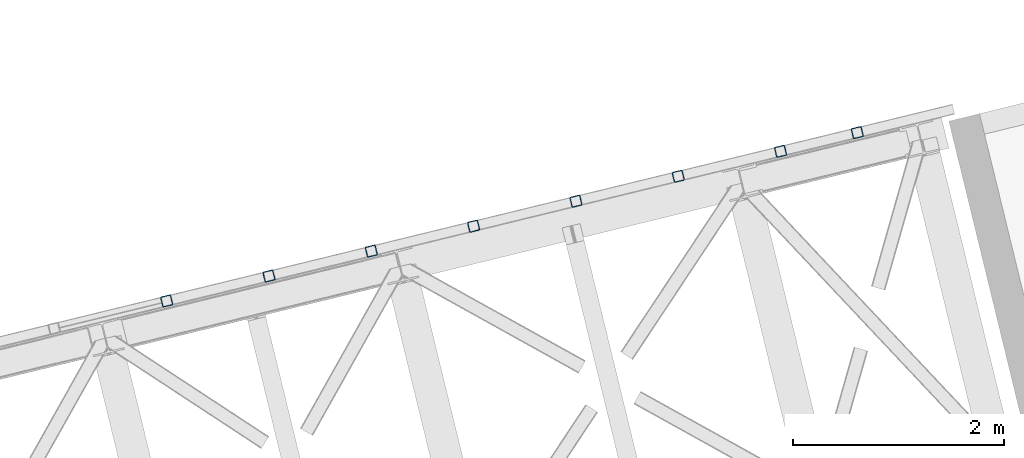
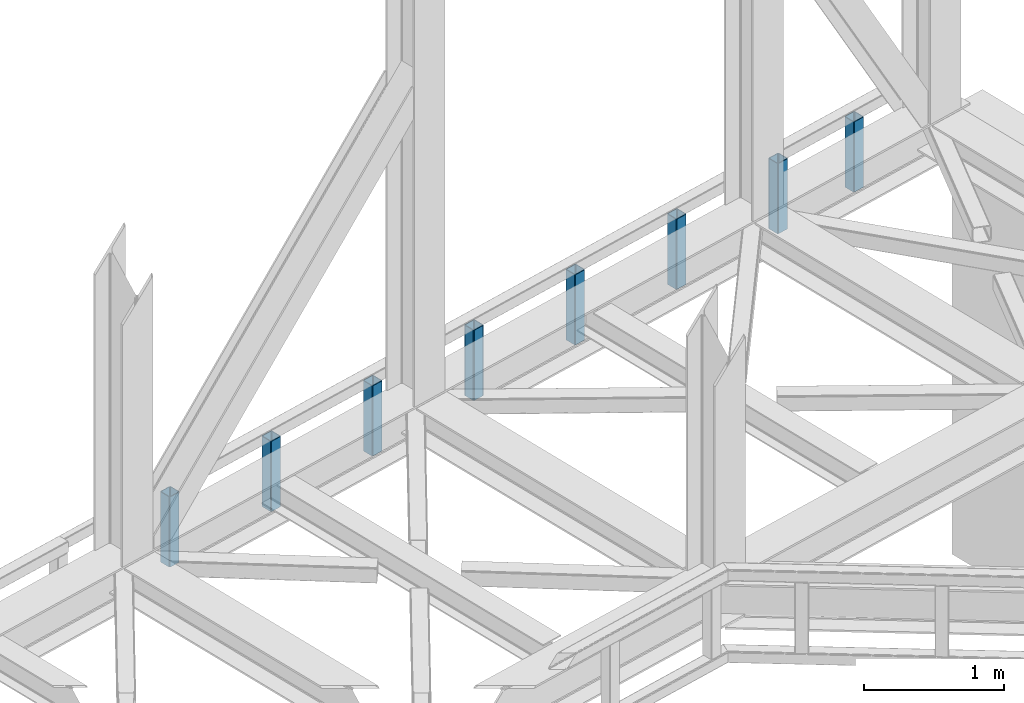
# One storey, part 14 of 93: 8 columns.
"""IFC4 building model written with IfcOpenShell, lengths in millimetres."""

from ifc_helpers import new_model, entity, si_unit, converted_unit, derived_unit, direction, frame, origin, place, context, subcontext, project, spatial, indexed_curve, outline, extrude, type_object, element, save


model = new_model("IFC4")

# Units and contexts
model_context = context("Model", 3, precision=0.01, world=origin(), true_north=direction((6.12303176911189e-17, 1.0)))
plan_context = context("Plan", 3, precision=0.01, world=origin(), true_north=direction((6.12303176911189e-17, 1.0)))
body_context = subcontext(model_context, "Body", "Model", "MODEL_VIEW")
ifc_project = project(units=[si_unit("LENGTHUNIT", "METRE", prefix="MILLI"), si_unit("AREAUNIT", "SQUARE_METRE"), si_unit("VOLUMEUNIT", "CUBIC_METRE"), converted_unit("PLANEANGLEUNIT", "DEGREE", entity("IfcRatioMeasure", 0.0174532925199433), si_unit("PLANEANGLEUNIT", "RADIAN"), dimensions=[0, 0, 0, 0, 0, 0, 0]), si_unit("MASSUNIT", "GRAM", prefix="KILO"), derived_unit("MASSDENSITYUNIT", [(si_unit("MASSUNIT", "GRAM", prefix="KILO"), 1), (si_unit("LENGTHUNIT", "METRE"), -3)]), derived_unit("MOMENTOFINERTIAUNIT", [(si_unit("LENGTHUNIT", "METRE"), 4)]), si_unit("TIMEUNIT", "SECOND"), si_unit("FREQUENCYUNIT", "HERTZ"), si_unit("THERMODYNAMICTEMPERATUREUNIT", "DEGREE_CELSIUS"), derived_unit("THERMALTRANSMITTANCEUNIT", [(si_unit("MASSUNIT", "GRAM", prefix="KILO"), 1), (si_unit("THERMODYNAMICTEMPERATUREUNIT", "KELVIN"), -1), (si_unit("TIMEUNIT", "SECOND"), -3)]), derived_unit("VOLUMETRICFLOWRATEUNIT", [(si_unit("LENGTHUNIT", "METRE"), 3), (si_unit("TIMEUNIT", "SECOND"), -1)]), derived_unit("MASSFLOWRATEUNIT", [(si_unit("MASSUNIT", "GRAM", prefix="KILO"), 1), (si_unit("TIMEUNIT", "SECOND"), -1)]), derived_unit("ROTATIONALFREQUENCYUNIT", [(si_unit("TIMEUNIT", "SECOND"), -1)]), si_unit("ELECTRICCURRENTUNIT", "AMPERE"), si_unit("ELECTRICVOLTAGEUNIT", "VOLT"), si_unit("POWERUNIT", "WATT"), si_unit("FORCEUNIT", "NEWTON", prefix="KILO"), si_unit("ILLUMINANCEUNIT", "LUX"), si_unit("LUMINOUSFLUXUNIT", "LUMEN"), si_unit("LUMINOUSINTENSITYUNIT", "CANDELA"), derived_unit("USERDEFINED", [(si_unit("MASSUNIT", "GRAM", prefix="KILO"), -1), (si_unit("LENGTHUNIT", "METRE"), -2), (si_unit("TIMEUNIT", "SECOND"), 3), (si_unit("LUMINOUSFLUXUNIT", "LUMEN"), 1)]), derived_unit("LINEARVELOCITYUNIT", [(si_unit("LENGTHUNIT", "METRE"), 1), (si_unit("TIMEUNIT", "SECOND"), -1)]), si_unit("PRESSUREUNIT", "PASCAL"), derived_unit("USERDEFINED", [(si_unit("LENGTHUNIT", "METRE"), -2), (si_unit("MASSUNIT", "GRAM", prefix="KILO"), 1), (si_unit("TIMEUNIT", "SECOND"), -2)]), derived_unit("LINEARFORCEUNIT", [(si_unit("MASSUNIT", "GRAM", prefix="KILO"), 1), (si_unit("LENGTHUNIT", "METRE"), 1), (si_unit("TIMEUNIT", "SECOND"), -2), (si_unit("LENGTHUNIT", "METRE"), -1)]), derived_unit("PLANARFORCEUNIT", [(si_unit("MASSUNIT", "GRAM", prefix="KILO"), 1), (si_unit("LENGTHUNIT", "METRE"), 1), (si_unit("TIMEUNIT", "SECOND"), -2), (si_unit("LENGTHUNIT", "METRE"), -2)])], contexts=[model_context, plan_context])

# Site, building, storey
site_placement = place(None, origin())
site = spatial("IfcSite", under=ifc_project, at=site_placement, CompositionType="ELEMENT")
building_placement = place(site_placement, origin())
building = spatial("IfcBuilding", under=site, at=building_placement, CompositionType="ELEMENT")
storey_placement = place(building_placement, frame((0.0, 0.0, 15900.0)))
storey = spatial("IfcBuildingStorey", under=building, at=storey_placement, CompositionType="ELEMENT", Elevation=15900.0)

# Columns
column_type_1 = type_object("IfcColumnType", PredefinedType="COLUMN")
column_1_placement = place(storey_placement, origin())
element("IfcColumn", 1, at=column_1_placement, inside=storey, type_object=column_type_1, ObjectType="Steel Column", PredefinedType="COLUMN", context=body_context, shape_type="SweptSolid", body=[
    extrude(outline(indexed_curve([(29.476895115349, -56.8428769007929), (33.37870155567, -56.8428769007929), (36.9835006657009, -55.3497202197826), (39.7424944585237, -52.5907264269531), (41.2356511395288, -48.9859273169178), (56.8428769007947, 29.4768951153464), (56.8428769007946, 33.3787015556698), (55.3497202197922, 36.9835006657036), (52.5907264269645, 39.7424944585291), (48.9859273169309, 41.2356511395364), (-29.4768951153304, 56.8428769008034), (-33.3787015556703, 56.8428769008026), (-36.983500665692, 55.3497202197928), (-39.742494458524, 52.5907264269628), (-41.2356511395382, 48.985927316927), (-56.8428769008028, -29.4768951153331), (-56.8428769007949, -33.3787015556601), (-55.3497202197833, -36.9835006656934), (-52.5907264269653, -39.7424944585192), (-48.9859273169146, -41.2356511395297), (29.476895115349, -56.8428769007929)], self_intersect=False), holes=[indexed_curve([(-43.1065493048278, -37.3071763475883), (-46.7113484148565, -35.8140196665833), (-49.4703422076867, -33.0550258737518), (-50.963498888688, -29.4502267637233), (-50.9634988886983, -25.5484203234), (-37.3071763475896, 43.1065493048314), (-35.8140196665759, 46.7113484148674), (-33.0550258737591, 49.4703422076902), (-29.4502267637216, 50.9634988887021), (-25.5484203234027, 50.9634988887079), (43.1065493048406, 37.3071763475967), (46.7113484148732, 35.8140196665899), (49.4703422077042, 33.0550258737675), (50.9634988887097, 29.4502267637276), (50.9634988887155, 25.5484203234063), (37.3071763476012, -43.1065493048272), (35.8140196665999, -46.7113484148594), (33.055025873766, -49.4703422076933), (29.4502267637393, -50.963498888696), (25.5484203234126, -50.9634988886982), (-43.1065493048278, -37.3071763475883)], self_intersect=False)]), frame((-2530.87393420391, 20381.2767648048, 3168.0), z_axis=(0.0, 0.0, 1.0), x_axis=(0.906681479027445, 0.4218159498983, 0.0)), (0.0, 0.0, 1.0), 612.000000000008),
])
column_type_2 = type_object("IfcColumnType", PredefinedType="COLUMN")
column_2_placement = place(storey_placement, origin())
element("IfcColumn", 2, at=column_2_placement, inside=storey, type_object=column_type_2, ObjectType="Steel Column", PredefinedType="COLUMN", context=body_context, shape_type="SweptSolid", body=[
    extrude(outline(indexed_curve([(29.476895115345, -56.8428769007958), (33.378701555666, -56.8428769007958), (36.9835006656971, -55.3497202197856), (39.7424944585291, -52.5907264269556), (41.2356511395342, -48.9859273169203), (56.8428769007987, 29.4768951153397), (56.8428769007984, 33.3787015556633), (55.3497202197884, 36.9835006657005), (52.590726426961, 39.742494458526), (48.9859273169274, 41.2356511395333), (-29.4768951153439, 56.8428769008001), (-33.3787015556647, 56.8428769008), (-36.9835006657036, 55.3497202197934), (-39.7424944585184, 52.5907264269601), (-41.2356511395328, 48.9859273169245), (-56.8428769007992, -29.4768951153395), (-56.8428769007892, -33.3787015556628), (-55.3497202197947, -36.9835006656929), (-52.5907264269596, -39.7424944585218), (-48.9859273169261, -41.2356511395291), (29.476895115345, -56.8428769007958)], self_intersect=False), holes=[indexed_curve([(-43.1065493048226, -37.3071763475907), (-46.7113484148589, -35.8140196665822), (-49.4703422076883, -33.0550258737558), (-50.9634988886878, -29.4502267637235), (-50.9634988886929, -25.5484203234025), (-37.3071763475806, 43.1065493048272), (-35.814019666583, 46.7113484148611), (-33.0550258737619, 49.470342207701), (-29.4502267637245, 50.9634988887035), (-25.548420323398, 50.9634988887057), (43.1065493048361, 37.307176347594), (46.711348414869, 35.8140196665871), (49.4703422076887, 33.0550258737604), (50.9634988887073, 29.4502267637335), (50.9634988887034, 25.5484203234071), (37.3071763475911, -43.1065493048225), (35.8140196665901, -46.7113484148644), (33.0550258737647, -49.4703422076879), (29.450226763735, -50.9634988886988), (25.5484203234099, -50.9634988886969), (-43.1065493048226, -37.3071763475907)], self_intersect=False)]), frame((-1802.20989059782, 20558.8963345476, 3168.0), z_axis=(0.0, 0.0, 1.0), x_axis=(0.906681479027445, 0.4218159498983, 0.0)), (0.0, 0.0, 1.0), 612.000000000008),
])
column_type_3 = type_object("IfcColumnType", PredefinedType="COLUMN")
column_3_placement = place(storey_placement, origin())
element("IfcColumn", 3, at=column_3_placement, inside=storey, type_object=column_type_3, ObjectType="Steel Column", PredefinedType="COLUMN", context=body_context, shape_type="SweptSolid", body=[
    extrude(outline(indexed_curve([(29.4768951153362, -56.8428769008013), (33.3787015556572, -56.8428769008013), (36.9835006656959, -55.3497202197946), (39.7424944585279, -52.5907264269646), (41.2356511395251, -48.9859273169257), (56.8428769007897, 29.4768951153344), (56.8428769007988, 33.3787015556583), (55.3497202197867, 36.9835006656918), (52.5907264269517, 39.7424944585208), (48.9859273169181, 41.235651139528), (-29.4768951153359, 56.8428769007916), (-33.3787015556661, 56.8428769007911), (-36.9835006656956, 55.3497202197849), (-39.7424944585369, 52.5907264269544), (-41.2356511395322, 48.9859273169194), (-56.8428769007986, -29.4768951153446), (-56.8428769008077, -33.3787015556685), (-55.3497202197869, -36.9835006657012), (-52.5907264269611, -39.7424944585307), (-48.9859273169183, -41.2356511395375), (29.4768951153362, -56.8428769008013)], self_intersect=False), holes=[indexed_curve([(-43.1065493048338, -37.3071763475999), (-46.7113484148666, -35.8140196665834), (-49.4703422076999, -33.0550258737647), (-50.9634988887023, -29.450226763731), (-50.9634988887121, -25.5484203234079), (-37.3071763476053, 43.1065493048196), (-35.8140196665908, 46.7113484148456), (-33.0550258737653, 49.4703422076834), (-29.4502267637372, 50.9634988886903), (-25.5484203234091, 50.9634988886966), (43.106549304825, 37.3071763475849), (46.7113484148594, 35.814019666582), (49.4703422076904, 33.0550258737596), (50.9634988887041, 29.4502267637206), (50.9634988887017, 25.5484203233984), (37.3071763475891, -43.1065493048312), (35.8140196665818, -46.7113484148701), (33.055025873744, -49.4703422077022), (29.4502267637237, -50.9634988887079), (25.5484203234066, -50.9634988887097), (-43.1065493048338, -37.3071763475999)], self_intersect=False)]), frame((-3502.42599234538, 20144.4506718145, 3168.0), z_axis=(0.0, 0.0, 1.0), x_axis=(0.906681479027445, 0.4218159498983, 0.0)), (0.0, 0.0, 1.0), 612.000000000008),
])
column_type_4 = type_object("IfcColumnType", PredefinedType="COLUMN")
column_4_placement = place(storey_placement, origin())
element("IfcColumn", 4, at=column_4_placement, inside=storey, type_object=column_type_4, ObjectType="Steel Column", PredefinedType="COLUMN", context=body_context, shape_type="SweptSolid", body=[
    extrude(outline(indexed_curve([(29.4768951152886, -56.8428769008306), (33.3787015556115, -56.8428769008306), (36.9835006656346, -55.3497202198244), (39.7424944584773, -52.5907264270008), (41.235651139486, -48.9859273169671), (56.8428769008309, 29.4768951152814), (56.8428769008347, 33.3787015556048), (55.3497202198189, 36.9835006656432), (52.5907264270037, 39.7424944584719), (48.9859273169698, 41.2356511394788), (-29.4768951152837, 56.8428769008284), (-33.3787015556066, 56.8428769008284), (-36.9835006656376, 55.3497202198258), (-39.7424944584719, 52.5907264269983), (-41.2356511394903, 48.9859273169643), (-56.8428769008356, -29.476895115284), (-56.8428769008298, -33.3787015556071), (-55.3497202198218, -36.9835006656418), (-52.5907264269988, -39.7424944584741), (-48.9859273169667, -41.235651139485), (29.4768951152886, -56.8428769008306)], self_intersect=False), holes=[indexed_curve([(-43.1065493048588, -37.3071763475528), (-46.7113484148957, -35.8140196665444), (-49.4703422077166, -33.0550258737036), (-50.9634988887208, -29.4502267636802), (-50.9634988887253, -25.5484203233529), (-37.3071763475476, 43.1065493048648), (-35.8140196665321, 46.7113484148953), (-33.0550258737185, 49.4703422077229), (-29.4502267636721, 50.9634988887278), (-25.5484203233453, 50.963498888726), (43.1065493048588, 37.3071763475528), (46.7113484149019, 35.8140196665463), (49.4703422077228, 33.0550258737055), (50.9634988887283, 29.4502267636719), (50.9634988887302, 25.5484203233506), (37.3071763475569, -43.1065493048691), (35.8140196665473, -46.7113484149024), (33.0550258737157, -49.4703422077264), (29.4502267636678, -50.9634988887306), (25.5484203233507, -50.9634988887285), (-43.1065493048588, -37.3071763475528)], self_intersect=False)]), frame((-4473.97805048686, 19907.6245788241, 3168.0), z_axis=(0.0, 0.0, 1.0), x_axis=(0.90668147902702, 0.421815949899212, 0.0)), (0.0, 0.0, 1.0), 612.000000000008),
])
column_type_5 = type_object("IfcColumnType", PredefinedType="COLUMN")
column_5_placement = place(storey_placement, origin())
element("IfcColumn", 5, at=column_5_placement, inside=storey, type_object=column_type_5, ObjectType="Steel Column", PredefinedType="COLUMN", context=body_context, shape_type="SweptSolid", body=[
    extrude(outline(indexed_curve([(29.4768951153449, -56.8428769008005), (33.3787015556659, -56.8428769008005), (36.9835006656972, -55.3497202197904), (39.7424944585201, -52.5907264269609), (41.2356511395246, -48.9859273169254), (56.8428769007915, 29.4768951153383), (56.8428769007905, 33.3787015556622), (55.3497202197885, 36.9835006656957), (52.5907264269614, 39.7424944585211), (48.9859273169273, 41.2356511395286), (-29.4768951153341, 56.8428769007955), (-33.3787015556569, 56.8428769007916), (-36.9835006656961, 55.3497202197851), (-39.7424944585277, 52.5907264269549), (-41.2356511395419, 48.9859273169191), (-56.8428769008069, -29.4768951153407), (-56.842876900799, -33.3787015556678), (-55.3497202197864, -36.9835006657015), (-52.5907264269514, -39.7424944585305), (-48.9859273169183, -41.2356511395375), (29.4768951153449, -56.8428769008005)], self_intersect=False), holes=[indexed_curve([(-43.1065493048309, -37.3071763475964), (-46.7113484148583, -35.8140196665873), (-49.4703422076876, -33.0550258737562), (-50.9634988886951, -29.4502267637296), (-50.9634988886922, -25.5484203234076), (-37.3071763475802, 43.1065493048222), (-35.8140196665777, 46.7113484148634), (-33.0550258737595, 49.4703422076855), (-29.4502267637242, 50.9634988886938), (-25.5484203234063, 50.9634988887), (43.106549304837, 37.3071763475888), (46.7113484148719, 35.8140196665857), (49.470342207695, 33.055025873767), (50.963498888706, 29.4502267637198), (50.963498888704, 25.5484203234021), (37.3071763475998, -43.1065493048313), (35.8140196665912, -46.7113484148601), (33.0550258737647, -49.4703422076975), (29.4502267637362, -50.9634988887041), (25.5484203234094, -50.9634988887062), (-43.1065493048309, -37.3071763475964)], self_intersect=False)]), frame((-5445.53010862834, 19670.7984858338, 3168.0), z_axis=(0.0, 0.0, 1.0), x_axis=(0.906681479027445, 0.4218159498983, 0.0)), (0.0, 0.0, 1.0), 612.000000000008),
])
column_type_6 = type_object("IfcColumnType", PredefinedType="COLUMN")
column_6_placement = place(storey_placement, origin())
element("IfcColumn", 6, at=column_6_placement, inside=storey, type_object=column_type_6, ObjectType="Steel Column", PredefinedType="COLUMN", context=body_context, shape_type="SweptSolid", body=[
    extrude(outline(indexed_curve([(29.4768951153477, -56.8428769007971), (33.3787015556687, -56.8428769007971), (36.9835006656913, -55.3497202197853), (39.7424944585219, -52.590726426957), (41.2356511395362, -48.9859273169237), (56.8428769008021, 29.4768951153406), (56.8428769007933, 33.3787015556657), (55.3497202197817, 36.9835006656989), (52.5907264269641, 39.742494458527), (48.9859273169301, 41.235651139532), (-29.4768951153419, 56.8428769007991), (-33.3787015556716, 56.8428769007984), (-36.9835006656933, 55.3497202197886), (-39.7424944585249, 52.5907264269584), (-41.2356511395304, 48.9859273169233), (-56.8428769007954, -29.4768951153389), (-56.8428769007953, -33.3787015556623), (-55.3497202197846, -36.9835006656975), (-52.5907264269671, -39.7424944585232), (-48.9859273169233, -41.2356511395304), (29.4768951153477, -56.8428769007971)], self_intersect=False), holes=[indexed_curve([(-43.1065493048213, -37.3071763475961), (-46.7113484148504, -35.8140196665933), (-49.4703422076942, -33.0550258737627), (-50.9634988886903, -29.450226763727), (-50.9634988887001, -25.5484203234039), (-37.3071763475929, 43.1065493048257), (-35.8140196665786, 46.7113484148615), (-33.0550258737509, 49.4703422076887), (-29.4502267637137, 50.9634988886985), (-25.5484203233966, 50.9634988887003), (43.10654930483, 37.3071763475944), (46.7113484148659, 35.8140196665933), (49.4703422076992, 33.0550258737555), (50.9634988887157, 29.4502267637224), (50.9634988887128, 25.5484203234004), (37.3071763476077, -43.106549304835), (35.8140196666, -46.7113484148618), (33.0550258737664, -49.4703422076911), (29.4502267637284, -50.9634988887029), (25.5484203234025, -50.9634988887006), (-43.1065493048213, -37.3071763475961)], self_intersect=False)]), frame((-6417.0821667698, 19433.9723928435, 3168.0), z_axis=(0.0, 0.0, 1.0), x_axis=(0.906681479027445, 0.4218159498983, 0.0)), (0.0, 0.0, 1.0), 612.000000000008),
])
column_type_7 = type_object("IfcColumnType", PredefinedType="COLUMN")
column_7_placement = place(storey_placement, origin())
element("IfcColumn", 7, at=column_7_placement, inside=storey, type_object=column_type_7, ObjectType="Steel Column", PredefinedType="COLUMN", context=body_context, shape_type="SweptSolid", body=[
    extrude(outline(indexed_curve([(29.4768951153389, -56.8428769007929), (33.3787015556599, -56.8428769007929), (36.9835006656981, -55.349720219786), (39.7424944585306, -52.5907264269562), (41.2356511395264, -48.9859273169191), (56.8428769007933, 29.4768951153447), (56.842876900801, 33.3787015556669), (55.3497202197894, 36.9835006657001), (52.5907264269544, 39.7424944585291), (48.9859273169203, 41.2356511395366), (-29.4768951153332, 56.8428769007999), (-33.3787015556552, 56.8428769007979), (-36.9835006657021, 55.3497202197927), (-39.7424944585171, 52.5907264269595), (-41.2356511395227, 48.9859273169245), (-56.8428769007886, -29.4768951153397), (-56.8428769007876, -33.3787015556612), (-55.3497202197934, -36.9835006656934), (-52.5907264269497, -39.7424944585241), (-48.9859273169156, -41.2356511395292), (29.4768951153389, -56.8428769007929)], self_intersect=False), holes=[indexed_curve([(-43.1065493048301, -37.307176347592), (-46.7113484148643, -35.8140196665797), (-49.4703422076903, -33.0550258737621), (-50.963498888703, -29.4502267637235), (-50.9634988887002, -25.5484203234015), (-37.3071763475899, 43.1065493048243), (-35.8140196665854, 46.7113484148622), (-33.055025873752, 49.470342207694), (-29.4502267637303, 50.9634988887038), (-25.5484203234055, 50.9634988887044), (43.10654930483, 37.3071763475969), (46.7113484148641, 35.8140196665894), (49.4703422077019, 33.0550258737614), (50.9634988887068, 29.4502267637266), (50.9634988887049, 25.5484203234065), (37.3071763475937, -43.1065493048213), (35.8140196665853, -46.7113484148574), (33.0550258737663, -49.4703422076863), (29.4502267637273, -50.9634988887), (25.5484203234112, -50.9634988886999), (-43.1065493048301, -37.307176347592)], self_intersect=False)]), frame((-7388.6342249113, 19197.1462998531, 3168.0), z_axis=(0.0, 0.0, 1.0), x_axis=(0.906681479027445, 0.4218159498983, 0.0)), (0.0, 0.0, 1.0), 612.000000000008),
])
column_type_8 = type_object("IfcColumnType", PredefinedType="COLUMN")
column_8_placement = place(storey_placement, origin())
element("IfcColumn", 8, at=column_8_placement, inside=storey, type_object=column_type_8, ObjectType="Steel Column", PredefinedType="COLUMN", context=body_context, shape_type="SweptSolid", body=[
    extrude(outline(indexed_curve([(29.4768951153439, -56.8428769008001), (33.3787015556649, -56.8428769008001), (36.9835006656875, -55.3497202197883), (39.7424944585269, -52.5907264269617), (41.2356511395324, -48.9859273169267), (56.8428769007983, 29.4768951153376), (56.8428769007982, 33.378701555661), (55.3497202197779, 36.9835006656959), (52.5907264269603, 39.7424944585239), (48.9859273169263, 41.235651139529), (-29.476895115337, 56.8428769007944), (-33.3787015556667, 56.8428769007937), (-36.9835006657059, 55.3497202197873), (-39.7424944585286, 52.5907264269553), (-41.2356511395342, 48.9859273169203), (-56.8428769007991, -29.4768951153419), (-56.8428769007991, -33.3787015556654), (-55.3497202197972, -36.9835006656989), (-52.5907264269621, -39.7424944585279), (-48.9859273169194, -41.2356511395346), (29.4768951153439, -56.8428769008001)], self_intersect=False), holes=[indexed_curve([(-43.1065493048251, -37.3071763475992), (-46.711348414862, -35.8140196665927), (-49.4703422076902, -33.0550258737645), (-50.9634988886941, -29.4502267637301), (-50.9634988887039, -25.5484203234069), (-37.3071763475967, 43.1065493048227), (-35.8140196665843, 46.7113484148569), (-33.0550258737627, 49.4703422076942), (-29.4502267637254, 50.9634988886991), (-25.5484203234004, 50.9634988886973), (43.1065493048184, 37.3071763475951), (46.7113484148689, 35.8140196665895), (49.4703422076932, 33.0550258737631), (50.9634988887039, 29.4502267637255), (50.9634988887021, 25.548420323403), (37.30717634759, -43.1065493048268), (35.8140196665886, -46.7113484148709), (33.0550258737627, -49.4703422076942), (29.4502267637167, -50.9634988887023), (25.5484203233987, -50.9634988887036), (-43.1065493048251, -37.3071763475992)], self_intersect=False)]), frame((-8360.18628305275, 18960.3202068628, 3168.0), z_axis=(0.0, 0.0, 1.0), x_axis=(0.906681479027445, 0.4218159498983, 0.0)), (0.0, 0.0, 1.0), 612.000000000008),
])

save(model, "model.ifc")
